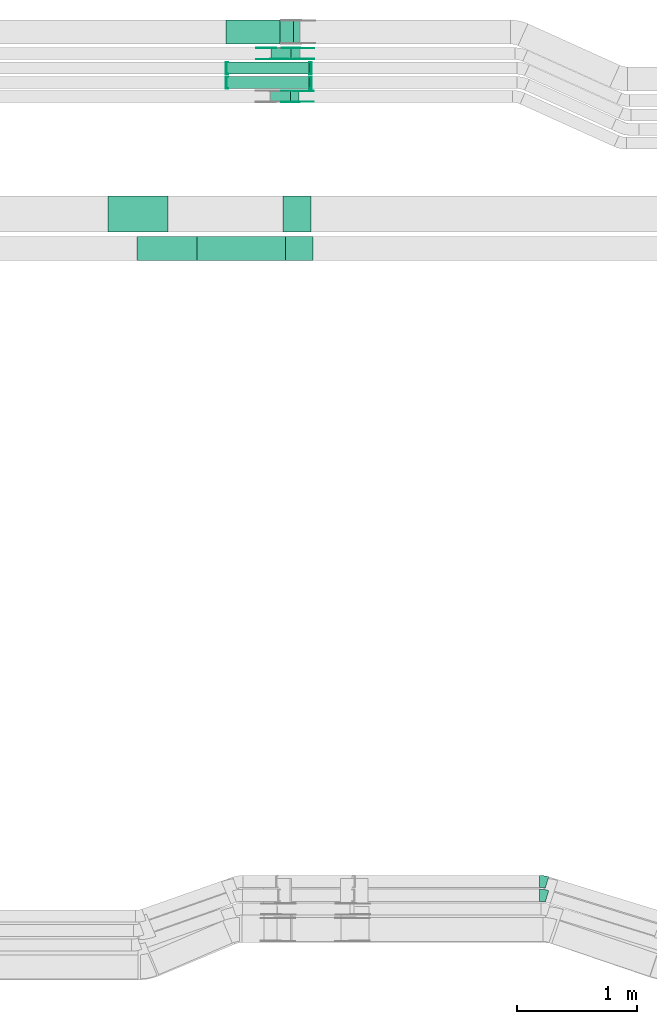
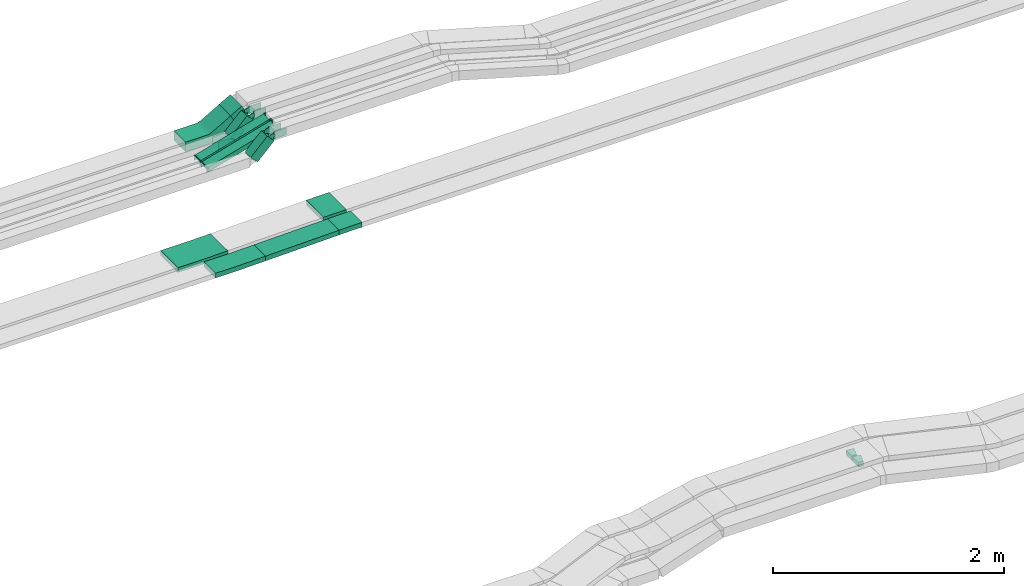
# One storey, part 11 of 31: 22 flow fittings, 6 flow segments.
"""IFC2X3 building model written with IfcOpenShell, lengths in millimetres."""

from ifc_helpers import new_model, entity, si_unit, converted_unit, derived_unit, direction, frame, frame_2d, origin, origin_2d_with_axis, place, context, subcontext, project, spatial, polyline, circle_curve, parameter, trimmed, segment, composite_curve, rectangle, outline, extrude, faceted_brep, source, transform, mapped, material, type_object, type_shapes, element, save


model = new_model("IFC2X3")

# Units and contexts
model_context = context("Model", 3, precision=0.01, world=origin(), true_north=direction((6.12303176911189e-17, 1.0)))
body_context = subcontext(model_context, "Body", "Model", "MODEL_VIEW")
ifc_project = project(units=[si_unit("LENGTHUNIT", "METRE", prefix="MILLI"), si_unit("AREAUNIT", "SQUARE_METRE"), si_unit("VOLUMEUNIT", "CUBIC_METRE"), converted_unit("PLANEANGLEUNIT", "DEGREE", entity("IfcRatioMeasure", 0.0174532925199433), si_unit("PLANEANGLEUNIT", "RADIAN"), dimensions=[0, 0, 0, 0, 0, 0, 0]), si_unit("MASSUNIT", "GRAM", prefix="KILO"), derived_unit("MASSDENSITYUNIT", [(si_unit("MASSUNIT", "GRAM", prefix="KILO"), 1), (si_unit("LENGTHUNIT", "METRE"), -3)]), derived_unit("MOMENTOFINERTIAUNIT", [(si_unit("LENGTHUNIT", "METRE"), 4)]), si_unit("TIMEUNIT", "SECOND"), si_unit("FREQUENCYUNIT", "HERTZ"), si_unit("THERMODYNAMICTEMPERATUREUNIT", "DEGREE_CELSIUS"), derived_unit("THERMALTRANSMITTANCEUNIT", [(si_unit("MASSUNIT", "GRAM", prefix="KILO"), 1), (si_unit("THERMODYNAMICTEMPERATUREUNIT", "KELVIN"), -1), (si_unit("TIMEUNIT", "SECOND"), -3)]), derived_unit("VOLUMETRICFLOWRATEUNIT", [(si_unit("LENGTHUNIT", "METRE"), 3), (si_unit("TIMEUNIT", "SECOND"), -1)]), derived_unit("MASSFLOWRATEUNIT", [(si_unit("MASSUNIT", "GRAM", prefix="KILO"), 1), (si_unit("TIMEUNIT", "SECOND"), -1)]), derived_unit("ROTATIONALFREQUENCYUNIT", [(si_unit("TIMEUNIT", "SECOND"), -1)]), si_unit("ELECTRICCURRENTUNIT", "AMPERE"), si_unit("ELECTRICVOLTAGEUNIT", "VOLT"), si_unit("POWERUNIT", "WATT"), si_unit("FORCEUNIT", "NEWTON", prefix="KILO"), si_unit("ILLUMINANCEUNIT", "LUX"), si_unit("LUMINOUSFLUXUNIT", "LUMEN"), si_unit("LUMINOUSINTENSITYUNIT", "CANDELA"), derived_unit("USERDEFINED", [(si_unit("MASSUNIT", "GRAM", prefix="KILO"), -1), (si_unit("LENGTHUNIT", "METRE"), -2), (si_unit("TIMEUNIT", "SECOND"), 3), (si_unit("LUMINOUSFLUXUNIT", "LUMEN"), 1)]), derived_unit("LINEARVELOCITYUNIT", [(si_unit("LENGTHUNIT", "METRE"), 1), (si_unit("TIMEUNIT", "SECOND"), -1)]), si_unit("PRESSUREUNIT", "PASCAL"), derived_unit("USERDEFINED", [(si_unit("LENGTHUNIT", "METRE"), -2), (si_unit("MASSUNIT", "GRAM", prefix="KILO"), 1), (si_unit("TIMEUNIT", "SECOND"), -2)]), derived_unit("LINEARFORCEUNIT", [(si_unit("MASSUNIT", "GRAM", prefix="KILO"), 1), (si_unit("LENGTHUNIT", "METRE"), 1), (si_unit("TIMEUNIT", "SECOND"), -2), (si_unit("LENGTHUNIT", "METRE"), -1)]), derived_unit("PLANARFORCEUNIT", [(si_unit("MASSUNIT", "GRAM", prefix="KILO"), 1), (si_unit("LENGTHUNIT", "METRE"), 1), (si_unit("TIMEUNIT", "SECOND"), -2), (si_unit("LENGTHUNIT", "METRE"), -2)])], contexts=[model_context])

# Site, building, storey
site_placement = place(None, frame((0.0, -0.00077364408347762, 0.0)))
site = spatial("IfcSite", under=ifc_project, at=site_placement, CompositionType="ELEMENT")
building_placement = place(site_placement, origin())
building = spatial("IfcBuilding", under=site, at=building_placement, CompositionType="ELEMENT")
storey_placement = place(building_placement, frame((0.0, 0.0, 15900.0)))
storey = spatial("IfcBuildingStorey", under=building, at=storey_placement, CompositionType="ELEMENT", Elevation=15900.0)

# Flow segments
cable_carrier_segment_type = type_object("IfcCableCarrierSegmentType", PredefinedType="CABLETRAYSEGMENT")
flow_segment_1_placement = place(storey_placement, frame((34281.4981442372, 15999.9939089947, 2768.97459621549)))
element("IfcFlowSegment", 1, at=flow_segment_1_placement, inside=storey, type_object=cable_carrier_segment_type, context=body_context, shape_type="SweptSolid", body=[
    extrude(rectangle(XDim=99.9999999999999, YDim=129.97901079922, at=frame_2d((0.0, 0.0), x_axis=(0.0, 1.0))), frame((81.2825626554492, 0.0, 75.7960228890284), z_axis=(0.0, 1.0, 0.0), x_axis=(-0.866025403784409, 0.0, -0.500000000000051)), (0.0, 0.0, 1.0), 200.000000000004),
])
flow_segment_2_placement = place(storey_placement, frame((34204.4851199811, 15869.9939089947, 2666.1680015377)))
element("IfcFlowSegment", 2, at=flow_segment_2_placement, inside=storey, type_object=cable_carrier_segment_type, context=body_context, shape_type="SweptSolid", body=[
    extrude(rectangle(XDim=100.000000000004, YDim=99.9999999999989, at=frame_2d((7.67386154620908e-13, 0.0), x_axis=(1.0, 0.0))), frame((35.355339059333, 50.0, 35.3553390593243), z_axis=(0.707106781186461, 0.0, 0.707106781186634), x_axis=(-0.707106781186634, 0.0, 0.707106781186461)), (0.0, 0.0, 1.0), 236.107647738385),
])
flow_segment_3_placement = place(storey_placement, frame((34200.9250285667, 15514.9939089947, 2666.1680015377)))
element("IfcFlowSegment", 3, at=flow_segment_3_placement, inside=storey, type_object=cable_carrier_segment_type, context=body_context, shape_type="SweptSolid", body=[
    extrude(rectangle(XDim=100.000000000002, YDim=99.9999999999989, at=frame_2d((7.60280727263307e-13, 0.0), x_axis=(1.0, 0.0))), frame((35.355339059333, 50.0, 35.3553390593243), z_axis=(0.70710678118645, 0.0, 0.707106781186645), x_axis=(-0.707106781186645, 0.0, 0.70710678118645)), (0.0, 0.0, 1.0), 236.046602434653),
])
flow_segment_4_placement = place(storey_placement, frame((33838.3721113622, 15629.4580000518, 2641.19260989608)))
element("IfcFlowSegment", 4, at=flow_segment_4_placement, inside=storey, type_object=cable_carrier_segment_type, context=body_context, shape_type="SweptSolid", body=[
    extrude(rectangle(XDim=49.9999999999985, YDim=99.9999999999989, at=origin_2d_with_axis()), frame((6.86802819743106, 50.0, 24.0380986910195), z_axis=(0.96152394764081, 0.0, 0.274721127897424), x_axis=(-0.274721127897424, 0.0, 0.96152394764081)), (0.0, 0.0, 1.0), 712.892453597831),
])
flow_segment_5_placement = place(storey_placement, frame((33838.3721113623, 15749.4580000519, 2641.19260989578)))
element("IfcFlowSegment", 5, at=flow_segment_5_placement, inside=storey, type_object=cable_carrier_segment_type, context=body_context, shape_type="SweptSolid", body=[
    extrude(rectangle(XDim=49.9999999999985, YDim=99.9999999999989, at=origin_2d_with_axis()), frame((6.86802819743106, 50.0, 24.0380986910195), z_axis=(0.96152394764081, 0.0, 0.274721127897424), x_axis=(-0.274721127897424, 0.0, 0.96152394764081)), (0.0, 0.0, 1.0), 712.892453597741),
])
flow_segment_6_placement = place(storey_placement, frame((33590.0405042145, 14200.0255085139, 2655.67453484739)))
element("IfcFlowSegment", 6, at=flow_segment_6_placement, inside=storey, type_object=cable_carrier_segment_type, context=body_context, shape_type="SweptSolid", body=[
    extrude(rectangle(XDim=50.0000000000022, YDim=199.999999999998, at=origin_2d_with_axis()), frame((0.567380405360097, 100.0, 24.9935607602372), z_axis=(0.999742430409444, 0.0, 0.0226952162144029), x_axis=(-0.0226952162144029, 0.0, 0.999742430409444)), (0.0, 0.0, 1.0), 737.074167716574),
])

# Flow fittings
ifc_material_1 = material()
cable_carrier_fitting_type_1 = type_object("IfcCableCarrierFittingType", Name="470_DKC_S5_Variable Angle Elbow 0-45:-", PredefinedType="NOTDEFINED", material=ifc_material_1)
shared_shape_1 = source(origin(), body_context, "Body", "SweptSolid", [
    extrude(outline(composite_curve([segment(polyline([(-30.3827359067082, -54.4910294125031), (-29.3827359067069, -54.4910294125031)]), True, "CONTINUOUS"), segment(trimmed(circle_curve(frame_2d((-29.3827359067074, 195.508970587497), x_axis=(0.0, -1.0)), 250.0), [parameter(0.0)], [parameter(17.0938540056406)], True, "PARAMETER"), True, "CONTINUOUS"), segment(polyline([(44.1017135160802, -43.4471670048022), (45.0575380664492, -43.1532292071111)]), True, "CONTINUOUS"), segment(polyline([(45.0575380664492, -43.1532292071111), (15.6637582973346, 52.4292258298085)]), True, "CONTINUOUS"), segment(polyline([(15.6637582973346, 52.4292258298085), (14.7079337469652, 52.1352880321173)]), True, "CONTINUOUS"), segment(trimmed(circle_curve(frame_2d((-29.3827359067074, 195.508970587497), x_axis=(0.0, -1.0)), 150.0), [parameter(0.0)], [parameter(17.0938540056406)], True, "PARAMETER"), False, "CONTINUOUS"), segment(polyline([(-29.3827359067069, 45.5089705874967), (-30.3827359067082, 45.5089705874967)]), True, "CONTINUOUS"), segment(polyline([(-30.3827359067082, 45.5089705874967), (-30.3827359067082, -54.4910294125031)]), True, "CONTINUOUS")], self_intersect=False)), frame((-0.67494975181135, 4.49102941249508, -25.0)), (0.0, 0.0, 1.0), 50.0000000000001),
])
type_shapes(cable_carrier_fitting_type_1, [shared_shape_1])
for number, where, z_axis, x_axis, name in (
    (7, (36471.7565759588, 8920.14880665488, 2735.63734545373), (0.0, 0.0, 1.0), (-0.955824550369197, 0.293937797691149, 0.0), "470_DKC_S5_Variable Angle Elbow 0-45:-"),
    (8, (36471.7565759588, 9035.14880665486, 2735.60211095119), (0.0, 0.0, 1.0), (-0.955824550369191, 0.293937797691167, 0.0), "470_DKC_S5_Variable Angle Elbow 0-45:-"),
):
    element("IfcFlowFitting", number, at=place(storey_placement, frame(where, z_axis=z_axis, x_axis=x_axis)), inside=storey, type_object=cable_carrier_fitting_type_1, material=ifc_material_1, Name=name, ObjectType="470_DKC_S5_Variable Angle Elbow 0-45:-", context=body_context, shape_type="MappedRepresentation", body=[
        mapped(shared_shape_1, transform((0.0, 0.0, 0.0), scale=1.0)),
    ])
ifc_material_2 = material(Name="G")
cable_carrier_fitting_type_2 = type_object("IfcCableCarrierFittingType", PredefinedType="NOTDEFINED", material=ifc_material_2)
shared_shape_2 = source(origin(), body_context, "Body", "SweptSolid", [
    extrude(outline(composite_curve([segment(trimmed(circle_curve(frame_2d((-41.4651162790697, 0.0), x_axis=(1.0, 0.0)), 25.0), [parameter(90.0000000000007)], [parameter(270.0)], True, "PARAMETER"), True, "CONTINUOUS"), segment(polyline([(-41.4651162790697, -25.0), (-29.9651162790697, -25.0)]), True, "CONTINUOUS"), segment(polyline([(-29.9651162790697, -25.0), (-28.1046511627907, -38.5)]), True, "CONTINUOUS"), segment(polyline([(-28.1046511627907, -38.5), (99.5348837209303, -38.5)]), True, "CONTINUOUS"), segment(polyline([(99.5348837209303, -38.5), (99.5348837209303, 38.5)]), True, "CONTINUOUS"), segment(polyline([(99.5348837209303, 38.5), (-28.1046511627907, 38.5)]), True, "CONTINUOUS"), segment(polyline([(-28.1046511627907, 38.5), (-29.9651162790697, 25.0)]), True, "CONTINUOUS"), segment(polyline([(-29.9651162790697, 25.0), (-41.46511627907, 25.0)]), True, "CONTINUOUS")], self_intersect=False)), frame((41.4651162790697, 0.0, 0.0), z_axis=(0.0, 0.0, -1.0), x_axis=(1.0, 0.0, 0.0)), (0.0, 0.0, -1.0), 2.0),
])
type_shapes(cable_carrier_fitting_type_2, [shared_shape_2])
for number, where, z_axis, x_axis in (
    (9, (34423.3171184433, 15874.5339089846, 2885.0), (0.0, -1.0, 0.0), (-0.707106781186429, 0.0, -0.707106781186666)),
    (10, (34419.7138614808, 15519.5339089846, 2884.95683445177), (0.0, -1.0, 0.0), (-0.707106781186429, 0.0, -0.707106781186666)),
    (11, (34223.3171184433, 15965.4539090049, 2685.0), (0.0, 1.0, 0.0), (-1.0, 0.0, 0.0)),
):
    element("IfcFlowFitting", number, at=place(storey_placement, frame(where, z_axis=z_axis, x_axis=x_axis)), inside=storey, type_object=cable_carrier_fitting_type_2, material=ifc_material_2, context=body_context, shape_type="MappedRepresentation", body=[
        mapped(shared_shape_2, transform((0.0, 0.0, 0.0), scale=1.0)),
    ])
cable_carrier_fitting_type_3 = type_object("IfcCableCarrierFittingType", PredefinedType="NOTDEFINED", material=ifc_material_2)
shared_shape_3 = source(origin(), body_context, "Body", "SweptSolid", [
    extrude(outline(composite_curve([segment(trimmed(circle_curve(frame_2d((-41.4651162790697, 0.0), x_axis=(1.0, 0.0)), 25.0), [parameter(90.0000000000007)], [parameter(270.0)], True, "PARAMETER"), True, "CONTINUOUS"), segment(polyline([(-41.4651162790697, -25.0), (-29.9651162790697, -25.0)]), True, "CONTINUOUS"), segment(polyline([(-29.9651162790697, -25.0), (-28.1046511627907, -38.5)]), True, "CONTINUOUS"), segment(polyline([(-28.1046511627907, -38.5), (99.5348837209303, -38.5)]), True, "CONTINUOUS"), segment(polyline([(99.5348837209303, -38.5), (99.5348837209303, 38.5)]), True, "CONTINUOUS"), segment(polyline([(99.5348837209303, 38.5), (-28.1046511627907, 38.5)]), True, "CONTINUOUS"), segment(polyline([(-28.1046511627907, 38.5), (-29.9651162790697, 25.0)]), True, "CONTINUOUS"), segment(polyline([(-29.9651162790697, 25.0), (-41.46511627907, 25.0)]), True, "CONTINUOUS")], self_intersect=False)), frame((41.4651162790697, 0.0, 0.0)), (0.0, 0.0, 1.0), 2.0),
])
type_shapes(cable_carrier_fitting_type_3, [shared_shape_3])
for number, where, z_axis, x_axis in (
    (12, (34423.3171184433, 15965.4539090049, 2885.0), (0.0, 1.0, 0.0), (-0.707106781186429, 0.0, -0.707106781186666)),
    (13, (34419.7138614808, 15610.4539090049, 2884.95683445177), (0.0, 1.0, 0.0), (-0.707106781186429, 0.0, -0.707106781186666)),
    (14, (34223.3171184433, 15874.5339089846, 2685.0), (0.0, -1.0, 0.0), (-1.0, 0.0, 0.0)),
):
    element("IfcFlowFitting", number, at=place(storey_placement, frame(where, z_axis=z_axis, x_axis=x_axis)), inside=storey, type_object=cable_carrier_fitting_type_3, material=ifc_material_2, context=body_context, shape_type="MappedRepresentation", body=[
        mapped(shared_shape_3, transform((0.0, 0.0, 0.0), scale=1.0)),
    ])
cable_carrier_fitting_type_4 = type_object("IfcCableCarrierFittingType", PredefinedType="NOTDEFINED", material=ifc_material_2)
shared_shape_4 = source(origin(), body_context, "Body", "SweptSolid", [
    extrude(outline(composite_curve([segment(trimmed(circle_curve(frame_2d((-41.4651162790697, 0.0), x_axis=(1.0, 0.0)), 25.0), [parameter(90.0000000000007)], [parameter(270.0)], True, "PARAMETER"), True, "CONTINUOUS"), segment(polyline([(-41.4651162790697, -25.0), (-29.9651162790697, -25.0)]), True, "CONTINUOUS"), segment(polyline([(-29.9651162790697, -25.0), (-28.1046511627907, -38.5)]), True, "CONTINUOUS"), segment(polyline([(-28.1046511627907, -38.5), (99.5348837209303, -38.5)]), True, "CONTINUOUS"), segment(polyline([(99.5348837209303, -38.5), (99.5348837209303, 38.5)]), True, "CONTINUOUS"), segment(polyline([(99.5348837209303, 38.5), (-28.1046511627907, 38.5)]), True, "CONTINUOUS"), segment(polyline([(-28.1046511627907, 38.5), (-29.9651162790697, 25.0)]), True, "CONTINUOUS"), segment(polyline([(-29.9651162790697, 25.0), (-41.46511627907, 25.0)]), True, "CONTINUOUS")], self_intersect=False)), frame((41.4651162790697, 0.0, 0.0), z_axis=(0.0, 0.0, -1.0), x_axis=(1.0, 0.0, 0.0)), (0.0, 0.0, -1.0), 2.0),
])
type_shapes(cable_carrier_fitting_type_4, [shared_shape_4])
for number, where, z_axis, x_axis in (
    (15, (34423.3171184433, 15963.4539090049, 2885.0), (0.0, 1.0, 0.0), (1.0, 0.0, 0.0)),
    (16, (34419.7138614807, 15608.4539090049, 2884.95683445177), (0.0, 1.0, 0.0), (1.0, 0.0, 0.0)),
    (17, (34223.3171184433, 15876.5339089846, 2685.0), (0.0, -1.0, 0.0), (0.707106781186433, 0.0, 0.707106781186662)),
):
    element("IfcFlowFitting", number, at=place(storey_placement, frame(where, z_axis=z_axis, x_axis=x_axis)), inside=storey, type_object=cable_carrier_fitting_type_4, material=ifc_material_2, context=body_context, shape_type="MappedRepresentation", body=[
        mapped(shared_shape_4, transform((0.0, 0.0, 0.0), scale=1.0)),
    ])
cable_carrier_fitting_type_5 = type_object("IfcCableCarrierFittingType", PredefinedType="NOTDEFINED", material=ifc_material_2)
shared_shape_5 = source(origin(), body_context, "Body", "SweptSolid", [
    extrude(outline(composite_curve([segment(trimmed(circle_curve(frame_2d((-41.4651162790697, 0.0), x_axis=(1.0, 0.0)), 25.0), [parameter(90.0000000000007)], [parameter(270.0)], True, "PARAMETER"), True, "CONTINUOUS"), segment(polyline([(-41.4651162790697, -25.0), (-29.9651162790697, -25.0)]), True, "CONTINUOUS"), segment(polyline([(-29.9651162790697, -25.0), (-28.1046511627907, -38.5)]), True, "CONTINUOUS"), segment(polyline([(-28.1046511627907, -38.5), (99.5348837209303, -38.5)]), True, "CONTINUOUS"), segment(polyline([(99.5348837209303, -38.5), (99.5348837209303, 38.5)]), True, "CONTINUOUS"), segment(polyline([(99.5348837209303, 38.5), (-28.1046511627907, 38.5)]), True, "CONTINUOUS"), segment(polyline([(-28.1046511627907, 38.5), (-29.9651162790697, 25.0)]), True, "CONTINUOUS"), segment(polyline([(-29.9651162790697, 25.0), (-41.46511627907, 25.0)]), True, "CONTINUOUS")], self_intersect=False)), frame((41.4651162790697, 0.0, 0.0)), (0.0, 0.0, 1.0), 2.0),
])
type_shapes(cable_carrier_fitting_type_5, [shared_shape_5])
for number, where, z_axis, x_axis in (
    (18, (34423.3171184433, 15876.5339089846, 2885.0), (0.0, -1.0, 0.0), (1.0, 0.0, 0.0)),
    (19, (34419.7138614807, 15521.5339089846, 2884.95683445177), (0.0, -1.0, 0.0), (1.0, 0.0, 0.0)),
):
    element("IfcFlowFitting", number, at=place(storey_placement, frame(where, z_axis=z_axis, x_axis=x_axis)), inside=storey, type_object=cable_carrier_fitting_type_5, material=ifc_material_2, context=body_context, shape_type="MappedRepresentation", body=[
        mapped(shared_shape_5, transform((0.0, 0.0, 0.0), scale=1.0)),
    ])
cable_carrier_fitting_type_6 = type_object("IfcCableCarrierFittingType", Name="470_DKC_S5_CS 90 internal vertical angle:-", PredefinedType="NOTDEFINED", material=ifc_material_1)
shared_shape_6 = source(origin(), body_context, "Body", "SweptSolid", [
    extrude(outline(composite_curve([segment(polyline([(-244.545058029216, -87.3454186950874), (-34.2049419707838, -87.3454186950874)]), True, "CONTINUOUS"), segment(trimmed(circle_curve(frame_2d((-34.2049419707841, 127.654581304911), x_axis=(0.0, -1.0)), 214.999999999999), [parameter(0.0)], [parameter(29.9999999999997)], True, "PARAMETER"), True, "CONTINUOUS"), segment(polyline([(73.2950580292147, -58.5408805087422), (255.454941970784, 46.6291775204725)]), True, "CONTINUOUS"), segment(polyline([(255.454941970784, 46.6291775204724), (205.454941970784, 133.231717898917)]), True, "CONTINUOUS"), segment(polyline([(205.454941970784, 133.231717898917), (23.2950580292149, 28.061659869702)]), True, "CONTINUOUS"), segment(trimmed(circle_curve(frame_2d((-34.2049419707841, 127.654581304911), x_axis=(0.0, -1.0)), 114.999999999999), [parameter(0.0)], [parameter(29.9999999999997)], True, "PARAMETER"), False, "CONTINUOUS"), segment(polyline([(-34.2049419707838, 12.6545813049128), (-244.545058029216, 12.6545813049129)]), True, "CONTINUOUS"), segment(polyline([(-244.545058029216, 12.6545813049129), (-244.545058029216, -87.3454186950874)]), True, "CONTINUOUS")], self_intersect=False)), frame((-10.0066747803419, 37.3454186950801, -100.0)), (0.0, 0.0, 1.0), 200.0),
])
type_shapes(cable_carrier_fitting_type_6, [shared_shape_6])
flow_fitting_1_placement = place(storey_placement, frame((34086.0498770468, 16099.9939089947, 2685.0), z_axis=(0.0, 1.0, 0.0), x_axis=(-0.866025403784432, 0.0, -0.500000000000012)))
element("IfcFlowFitting", 20, at=flow_fitting_1_placement, inside=storey, type_object=cable_carrier_fitting_type_6, material=ifc_material_1, Name="470_DKC_S5_CS 90 internal vertical angle:-", ObjectType="470_DKC_S5_CS 90 internal vertical angle:-", context=body_context, shape_type="MappedRepresentation", body=[
    mapped(shared_shape_6, transform((0.0, 0.0, 0.0), scale=1.0)),
])
cable_carrier_fitting_type_7 = type_object("IfcCableCarrierFittingType", PredefinedType="NOTDEFINED", material=ifc_material_1)
shared_shape_7 = source(origin(), body_context, "Body", "Brep", [
    faceted_brep([(-7.00274723201393, 25.0, 50.0), (-7.00274723201393, 25.0, -50.0), (-7.00274723201409, -25.0, -50.0), (-7.00274723201409, -25.0, -47.4600000101565), (-7.00274723201394, 22.46000001016, -47.4600000101565), (-7.00274723201394, 22.46000001016, 47.4600000101635), (-7.00274723201409, -25.0, 47.4600000101635), (-7.00274723201409, -25.0, 50.0), (-0.134719034578017, 25.9619013089794, 50.0), (13.6013373602937, -22.114296073061, 50.0), (13.6013373602937, -22.114296073061, 47.4600000101635), (0.5630726274903, 23.5196304917408, 47.4600000101635), (0.563072627490299, 23.5196304917408, -47.4600000101565), (13.6013373602937, -22.114296073061, -47.4600000101565), (13.6013373602937, -22.114296073061, -50.0), (-0.134719034578017, 25.9619013089794, -50.0), (-3.50137361600667, 25.0, 50.0), (-3.50137361600674, 25.0, -50.0), (3.50137361600763, -25.0, -50.0), (3.50137361600763, -25.0, -47.4600000101565), (-3.14563405804336, 22.46000001016, -47.4600000101565), (-3.14563405804336, 22.46000001016, 47.4600000101635), (3.50137361600763, -25.0, 47.4600000101635), (3.50137361600763, -25.0, 50.0)], [[[0, 1, 2, 3, 4, 5, 6, 7]], [[8, 9, 10, 11, 12, 13, 14, 15]], [[1, 0, 16, 17]], [[2, 1, 17, 15, 14, 18]], [[3, 2, 18, 19]], [[4, 3, 19, 13, 12, 20]], [[5, 4, 20, 21]], [[6, 5, 21, 11, 10, 22]], [[7, 6, 22, 23]], [[0, 7, 23, 9, 8, 16]], [[17, 16, 8, 15]], [[19, 18, 14, 13]], [[21, 20, 12, 11]], [[23, 22, 10, 9]]]),
])
type_shapes(cable_carrier_fitting_type_7, [shared_shape_7])
for number, where, z_axis, x_axis in (
    (21, (34537.4366149492, 15799.4580000519, 2863.00113012665), (0.0, 1.0, 0.0), (0.961523947640807, 0.0, 0.274721127897435)),
    (22, (34537.4366149492, 15679.4580000518, 2863.00113012698), (0.0, 1.0, 0.0), (0.961523947640807, 0.0, 0.274721127897435)),
    (23, (33838.5068303969, 15799.4580000519, 2663.30690596885), (0.0, 1.0, 0.0), (-0.961523947640821, 0.0, -0.274721127897387)),
    (24, (33838.5068303968, 15679.4580000518, 2663.30690596915), (0.0, 1.0, 0.0), (-0.961523947640823, 0.0, -0.274721127897379)),
):
    element("IfcFlowFitting", number, at=place(storey_placement, frame(where, z_axis=z_axis, x_axis=x_axis)), inside=storey, type_object=cable_carrier_fitting_type_7, material=ifc_material_1, context=body_context, shape_type="MappedRepresentation", body=[
        mapped(shared_shape_7, transform((0.0, 0.0, 0.0), scale=1.0)),
    ])
cable_carrier_fitting_type_8 = type_object("IfcCableCarrierFittingType", Name="470_DKC_S5_CD 90 external vertical angle:-", PredefinedType="NOTDEFINED", material=ifc_material_1)
shared_shape_8 = source(origin(), body_context, "Body", "SweptSolid", [
    extrude(outline(composite_curve([segment(polyline([(-114.723577026016, -25.6615864431197), (-1.86508810898775, -25.6615864431197)]), True, "CONTINUOUS"), segment(trimmed(circle_curve(frame_2d((-1.86508810898808, 164.338413556879), x_axis=(0.0, -1.0)), 189.999999999999), [parameter(0.0)], [parameter(1.30045175841151)], True, "PARAMETER"), True, "CONTINUOUS"), segment(polyline([(2.44700297173669, -25.6126482209144), (115.276422973984, -23.0513004133188)]), True, "CONTINUOUS"), segment(polyline([(115.276422973984, -23.0513004133188), (114.141662163267, 26.9358211071537)]), True, "CONTINUOUS"), segment(polyline([(114.141662163267, 26.9358211071537), (1.31224216101963, 24.3744732995582)]), True, "CONTINUOUS"), segment(trimmed(circle_curve(frame_2d((-1.86508810898808, 164.338413556879), x_axis=(0.0, -1.0)), 139.999999999999), [parameter(0.0)], [parameter(1.30045175841151)], True, "PARAMETER"), False, "CONTINUOUS"), segment(polyline([(-1.86508810898775, 24.3384135568805), (-114.723577026016, 24.3384135568805)]), True, "CONTINUOUS"), segment(polyline([(-114.723577026016, 24.3384135568805), (-114.723577026016, -25.6615864431197)]), True, "CONTINUOUS")], self_intersect=False)), frame((-0.00750839064298544, 0.661586443112432, -100.0)), (0.0, 0.0, 1.0), 200.0),
])
type_shapes(cable_carrier_fitting_type_8, [shared_shape_8])
flow_fitting_2_placement = place(storey_placement, frame((34442.1937386228, 14300.0255085139, 2700.0), z_axis=(0.0, -1.0, 0.0), x_axis=(-1.0, 0.0, 0.0)))
element("IfcFlowFitting", 25, at=flow_fitting_2_placement, inside=storey, type_object=cable_carrier_fitting_type_8, material=ifc_material_1, Name="470_DKC_S5_CD 90 external vertical angle:-", ObjectType="470_DKC_S5_CD 90 external vertical angle:-", context=body_context, shape_type="MappedRepresentation", body=[
    mapped(shared_shape_8, transform((0.0, 0.0, 0.0), scale=1.0)),
])
cable_carrier_fitting_type_9 = type_object("IfcCableCarrierFittingType", Name="470_DKC_S5_CD 90 external vertical angle:-", PredefinedType="NOTDEFINED", material=ifc_material_1)
shared_shape_9 = source(origin(), body_context, "Body", "SweptSolid", [
    extrude(outline(composite_curve([segment(polyline([(-114.76859253839, -25.5501990355294), (-1.55565369751285, -25.5501990355294)]), True, "CONTINUOUS"), segment(trimmed(circle_curve(frame_2d((-1.5556536975132, 164.449800964469), x_axis=(0.0, -1.0)), 189.999999999999), [parameter(0.0)], [parameter(1.08397495340498)], True, "PARAMETER"), True, "CONTINUOUS"), segment(polyline([(2.03872894279447, -25.5161970810614), (115.23140746161, -23.3744569651254)]), True, "CONTINUOUS"), segment(polyline([(115.23140746161, -23.3744569651254), (114.285517293108, 26.6165951521201)]), True, "CONTINUOUS"), segment(polyline([(114.285517293108, 26.6165951521201), (1.09283877429245, 24.4748550361842)]), True, "CONTINUOUS"), segment(trimmed(circle_curve(frame_2d((-1.5556536975132, 164.449800964469), x_axis=(0.0, -1.0)), 139.999999999999), [parameter(0.0)], [parameter(1.08397495340498)], True, "PARAMETER"), False, "CONTINUOUS"), segment(polyline([(-1.55565369751285, 24.4498009644709), (-114.76859253839, 24.4498009644709)]), True, "CONTINUOUS"), segment(polyline([(-114.76859253839, 24.4498009644709), (-114.76859253839, -25.5501990355293)]), True, "CONTINUOUS")], self_intersect=False)), frame((-0.00520474428958647, 0.550199035522148, -150.0)), (0.0, 0.0, 1.0), 300.0),
])
type_shapes(cable_carrier_fitting_type_9, [shared_shape_9])
flow_fitting_3_placement = place(storey_placement, frame((34422.1937386228, 14585.0255085139, 2700.0), z_axis=(0.0, -1.0, 0.0), x_axis=(-1.0, 0.0, 0.0)))
element("IfcFlowFitting", 26, at=flow_fitting_3_placement, inside=storey, type_object=cable_carrier_fitting_type_9, material=ifc_material_1, Name="470_DKC_S5_CD 90 external vertical angle:-", ObjectType="470_DKC_S5_CD 90 external vertical angle:-", context=body_context, shape_type="MappedRepresentation", body=[
    mapped(shared_shape_9, transform((0.0, 0.0, 0.0), scale=1.0)),
])
cable_carrier_fitting_type_10 = type_object("IfcCableCarrierFittingType", Name="470_DKC_S5_CS 90 internal vertical angle:-", PredefinedType="NOTDEFINED", material=ifc_material_1)
shared_shape_10 = source(origin(), body_context, "Body", "SweptSolid", [
    extrude(outline(composite_curve([segment(polyline([(-249.73228938921, -26.4260388375763), (-1.57268554311437, -26.4260388375763)]), True, "CONTINUOUS"), segment(trimmed(circle_curve(frame_2d((-1.57268554311464, 138.573961162423), x_axis=(0.0, -1.0)), 164.999999999999), [parameter(0.0)], [parameter(1.30045175841095)], True, "PARAMETER"), True, "CONTINUOUS"), segment(polyline([(2.17202513224996, -26.3835398551348), (250.26771061079, -20.7515039901853)]), True, "CONTINUOUS"), segment(polyline([(250.26771061079, -20.7515039901854), (249.132949800074, 29.2356175302872)]), True, "CONTINUOUS"), segment(polyline([(249.132949800074, 29.2356175302872), (1.03726432153339, 23.6035816653378)]), True, "CONTINUOUS"), segment(trimmed(circle_curve(frame_2d((-1.57268554311464, 138.573961162423), x_axis=(0.0, -1.0)), 114.999999999999), [parameter(0.0)], [parameter(1.30045175841095)], True, "PARAMETER"), False, "CONTINUOUS"), segment(polyline([(-1.57268554311437, 23.573961162424), (-249.73228938921, 23.573961162424)]), True, "CONTINUOUS"), segment(polyline([(-249.73228938921, 23.573961162424), (-249.73228938921, -26.4260388375762)]), True, "CONTINUOUS")], self_intersect=False)), frame((-0.0161842141460725, 1.42603883756892, -100.0)), (0.0, 0.0, 1.0), 200.0),
])
type_shapes(cable_carrier_fitting_type_10, [shared_shape_10])
flow_fitting_4_placement = place(storey_placement, frame((33340.9237386291, 14300.0255085139, 2675.0), z_axis=(0.0, 1.0, 0.0), x_axis=(-0.999742430409445, 0.0, -0.0226952162143693)))
element("IfcFlowFitting", 27, at=flow_fitting_4_placement, inside=storey, type_object=cable_carrier_fitting_type_10, material=ifc_material_1, Name="470_DKC_S5_CS 90 internal vertical angle:-", ObjectType="470_DKC_S5_CS 90 internal vertical angle:-", context=body_context, shape_type="MappedRepresentation", body=[
    mapped(shared_shape_10, transform((0.0, 0.0, 0.0), scale=1.0)),
])
cable_carrier_fitting_type_11 = type_object("IfcCableCarrierFittingType", Name="470_DKC_S5_CS 90 internal vertical angle:-", PredefinedType="NOTDEFINED", material=ifc_material_1)
shared_shape_11 = source(origin(), body_context, "Body", "SweptSolid", [
    extrude(outline(composite_curve([segment(polyline([(-249.774643480324, -26.1876135491075), (-1.31313021345333, -26.1876135491075)]), True, "CONTINUOUS"), segment(trimmed(circle_curve(frame_2d((-1.31313021345363, 138.812386450891), x_axis=(0.0, -1.0)), 164.999999999999), [parameter(0.0)], [parameter(1.08397495340462)], True, "PARAMETER"), True, "CONTINUOUS"), segment(polyline([(1.80830734260188, -26.1580855360168), (250.225356519677, -21.4577394830137)]), True, "CONTINUOUS"), segment(polyline([(250.225356519676, -21.4577394830137), (249.279466351175, 28.5333126342318)]), True, "CONTINUOUS"), segment(polyline([(249.279466351175, 28.5333126342318), (0.86241717410021, 23.8329665812287)]), True, "CONTINUOUS"), segment(trimmed(circle_curve(frame_2d((-1.31313021345363, 138.812386450891), x_axis=(0.0, -1.0)), 114.999999999999), [parameter(0.0)], [parameter(1.08397495340462)], True, "PARAMETER"), False, "CONTINUOUS"), segment(polyline([(-1.31313021345333, 23.8123864508928), (-249.774643480324, 23.8123864508928)]), True, "CONTINUOUS"), segment(polyline([(-249.774643480324, 23.8123864508928), (-249.774643480324, -26.1876135491075)]), True, "CONTINUOUS")], self_intersect=False)), frame((-0.0112345250438856, 1.18761354910024, -150.0)), (0.0, 0.0, 1.0), 300.0),
])
type_shapes(cable_carrier_fitting_type_11, [shared_shape_11])
flow_fitting_5_placement = place(storey_placement, frame((33100.9237386254, 14585.0255085139, 2675.0), z_axis=(0.0, 1.0, 0.0), x_axis=(-0.999821042344905, 0.0, -0.0189178033700457)))
element("IfcFlowFitting", 28, at=flow_fitting_5_placement, inside=storey, type_object=cable_carrier_fitting_type_11, material=ifc_material_1, Name="470_DKC_S5_CS 90 internal vertical angle:-", ObjectType="470_DKC_S5_CS 90 internal vertical angle:-", context=body_context, shape_type="MappedRepresentation", body=[
    mapped(shared_shape_11, transform((0.0, 0.0, 0.0), scale=1.0)),
])

save(model, "model.ifc")
